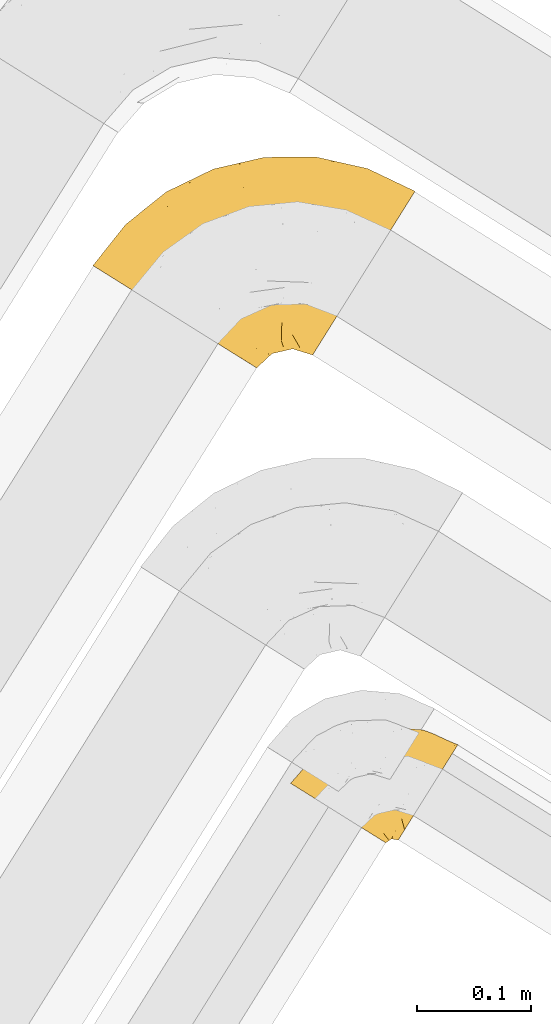
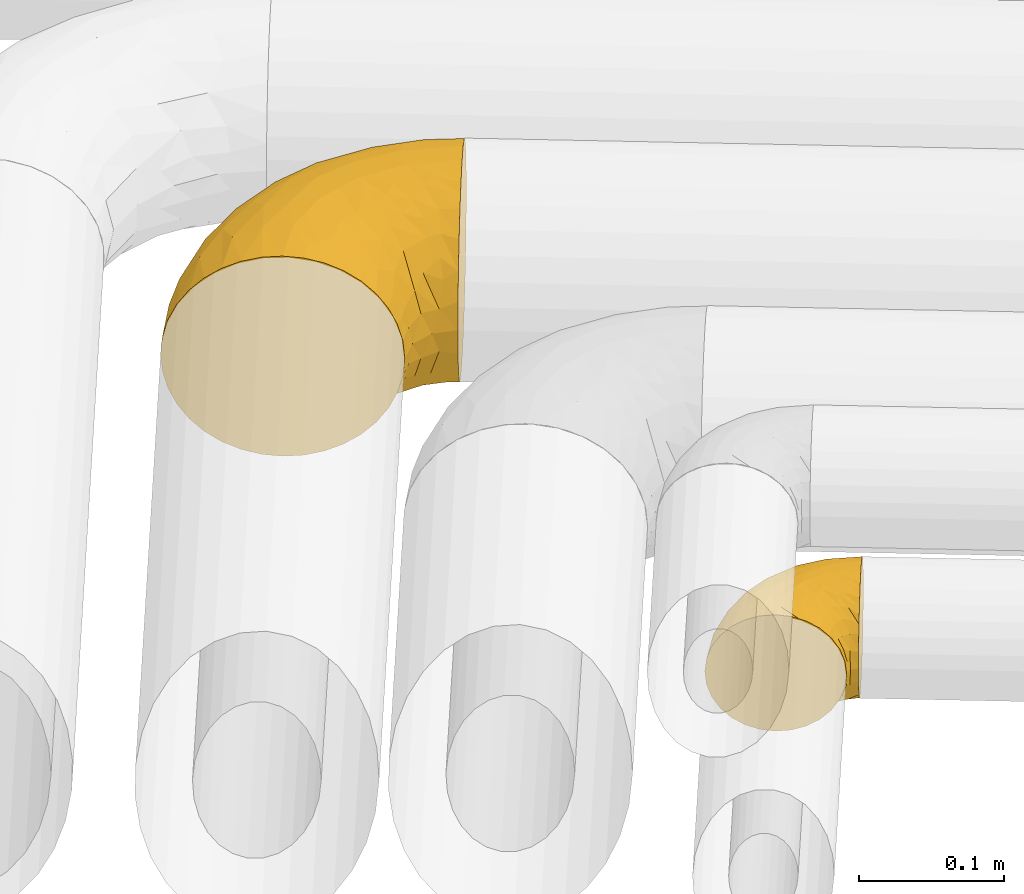
# One storey, part 24 of 93: 2 coverings.
"""IFC2X3 building model written with IfcOpenShell, lengths in millimetres."""

from ifc_helpers import new_model, entity, si_unit, converted_unit, derived_unit, direction, frame, origin, place, context, subcontext, project, spatial, faceted_brep, element, save


model = new_model("IFC2X3")

# Units and contexts
model_context = context("Model", 3, precision=0.01, world=origin(), true_north=direction((6.12303176911189e-17, 1.0)))
body_context = subcontext(model_context, "Body", "Model", "MODEL_VIEW")
ifc_project = project(units=[si_unit("LENGTHUNIT", "METRE", prefix="MILLI"), si_unit("AREAUNIT", "SQUARE_METRE"), si_unit("VOLUMEUNIT", "CUBIC_METRE"), converted_unit("PLANEANGLEUNIT", "DEGREE", entity("IfcRatioMeasure", 0.0174532925199433), si_unit("PLANEANGLEUNIT", "RADIAN"), dimensions=[0, 0, 0, 0, 0, 0, 0]), si_unit("MASSUNIT", "GRAM", prefix="KILO"), derived_unit("MASSDENSITYUNIT", [(si_unit("MASSUNIT", "GRAM", prefix="KILO"), 1), (si_unit("LENGTHUNIT", "METRE"), -3)]), derived_unit("MOMENTOFINERTIAUNIT", [(si_unit("LENGTHUNIT", "METRE"), 4)]), si_unit("TIMEUNIT", "SECOND"), si_unit("FREQUENCYUNIT", "HERTZ"), si_unit("THERMODYNAMICTEMPERATUREUNIT", "DEGREE_CELSIUS"), derived_unit("THERMALTRANSMITTANCEUNIT", [(si_unit("MASSUNIT", "GRAM", prefix="KILO"), 1), (si_unit("THERMODYNAMICTEMPERATUREUNIT", "KELVIN"), -1), (si_unit("TIMEUNIT", "SECOND"), -3)]), derived_unit("VOLUMETRICFLOWRATEUNIT", [(si_unit("LENGTHUNIT", "METRE"), 3), (si_unit("TIMEUNIT", "SECOND"), -1)]), derived_unit("MASSFLOWRATEUNIT", [(si_unit("MASSUNIT", "GRAM", prefix="KILO"), 1), (si_unit("TIMEUNIT", "SECOND"), -1)]), derived_unit("ROTATIONALFREQUENCYUNIT", [(si_unit("TIMEUNIT", "SECOND"), -1)]), si_unit("ELECTRICCURRENTUNIT", "AMPERE"), si_unit("ELECTRICVOLTAGEUNIT", "VOLT"), si_unit("POWERUNIT", "WATT"), si_unit("FORCEUNIT", "NEWTON", prefix="KILO"), si_unit("ILLUMINANCEUNIT", "LUX"), si_unit("LUMINOUSFLUXUNIT", "LUMEN"), si_unit("LUMINOUSINTENSITYUNIT", "CANDELA"), derived_unit("USERDEFINED", [(si_unit("MASSUNIT", "GRAM", prefix="KILO"), -1), (si_unit("LENGTHUNIT", "METRE"), -2), (si_unit("TIMEUNIT", "SECOND"), 3), (si_unit("LUMINOUSFLUXUNIT", "LUMEN"), 1)]), derived_unit("LINEARVELOCITYUNIT", [(si_unit("LENGTHUNIT", "METRE"), 1), (si_unit("TIMEUNIT", "SECOND"), -1)]), si_unit("PRESSUREUNIT", "PASCAL"), derived_unit("USERDEFINED", [(si_unit("LENGTHUNIT", "METRE"), -2), (si_unit("MASSUNIT", "GRAM", prefix="KILO"), 1), (si_unit("TIMEUNIT", "SECOND"), -2)]), derived_unit("LINEARFORCEUNIT", [(si_unit("MASSUNIT", "GRAM", prefix="KILO"), 1), (si_unit("LENGTHUNIT", "METRE"), 1), (si_unit("TIMEUNIT", "SECOND"), -2), (si_unit("LENGTHUNIT", "METRE"), -1)]), derived_unit("PLANARFORCEUNIT", [(si_unit("MASSUNIT", "GRAM", prefix="KILO"), 1), (si_unit("LENGTHUNIT", "METRE"), 1), (si_unit("TIMEUNIT", "SECOND"), -2), (si_unit("LENGTHUNIT", "METRE"), -2)])], contexts=[model_context])

# Site, building, storey
site_placement = place(None, origin())
site = spatial("IfcSite", under=ifc_project, at=site_placement, CompositionType="ELEMENT")
building_placement = place(site_placement, origin())
building = spatial("IfcBuilding", under=site, at=building_placement, CompositionType="ELEMENT")
storey_placement = place(building_placement, frame((0.0, 0.0, -4200.0)))
storey = spatial("IfcBuildingStorey", under=building, at=storey_placement, CompositionType="ELEMENT", Elevation=-4200.0)

# Coverings
covering_1_placement = place(storey_placement, frame((15989.6, 11181.06, 2910.91)))
element("IfcCovering", 1, at=covering_1_placement, inside=storey, Name=":ADSK_", ObjectType=":ADSK_", PredefinedType="INSULATION", context=body_context, shape_type="Brep", body=[
    faceted_brep([(48.74, 61.69, 165.5), (37.42, 68.77, 159.27), (27.19, 75.16, 150.82), (18.36, 80.68, 140.41), (11.2, 85.15, 128.34), (5.92, 88.45, 115.0), (2.68, 90.47, 100.77), (1.6, 91.15, 86.1), (2.68, 90.47, 71.42), (5.92, 88.45, 57.19), (11.2, 85.15, 43.84), (18.36, 80.67, 31.78), (27.19, 75.16, 21.36), (37.43, 68.76, 12.92), (48.75, 61.69, 6.69), (60.81, 54.15, 2.88), (73.26, 46.37, 1.6), (85.7, 38.6, 2.88), (97.77, 31.06, 6.69), (109.09, 23.98, 12.92), (119.32, 17.59, 21.37), (128.15, 12.07, 31.78), (135.31, 7.59, 43.85), (140.59, 4.3, 57.19), (143.83, 2.28, 71.42), (144.92, 1.6, 86.1), (143.83, 2.28, 100.77), (140.59, 4.3, 115.0), (135.31, 7.6, 128.35), (128.15, 12.07, 140.41), (119.32, 17.59, 150.83), (109.09, 23.98, 159.27), (97.77, 31.06, 165.5), (91.73, 34.83, 167.41), (85.7, 38.6, 169.31), (73.26, 46.37, 170.6), (60.81, 54.15, 169.31), (193.83, 12.89, 86.1), (195.36, 15.33, 64.23), (199.83, 22.49, 43.85), (206.95, 33.88, 26.34), (216.22, 48.72, 12.92), (227.02, 66.0, 4.47), (231.48, 73.13, 3.37), (238.61, 84.55, 1.6), (250.2, 103.1, 4.47), (261.0, 120.38, 12.92), (270.27, 135.22, 26.34), (277.39, 146.61, 43.85), (281.86, 153.77, 64.23), (283.39, 156.21, 86.1), (281.86, 153.77, 107.97), (277.39, 146.61, 128.35), (270.27, 135.22, 145.85), (261.0, 120.38, 159.27), (250.2, 103.1, 167.72), (238.61, 84.55, 170.6), (231.48, 73.13, 168.82), (227.02, 66.0, 167.72), (221.62, 57.36, 163.5), (216.22, 48.72, 159.27), (206.95, 33.88, 145.85), (199.83, 22.49, 128.35), (195.36, 15.33, 107.97), (242.08, 175.98, 86.1), (197.41, 186.05, 86.1), (211.24, 182.55, 101.8), (243.27, 174.05, 101.53), (232.04, 173.74, 115.31), (132.92, 159.31, 144.07), (162.05, 153.18, 153.55), (172.26, 167.01, 140.98), (151.62, 185.94, 86.1), (175.13, 185.81, 101.78), (221.31, 133.45, 161.76), (93.97, 146.55, 142.72), (68.18, 120.64, 150.74), (99.34, 132.99, 155.51), (42.65, 108.25, 143.09), (129.5, 179.97, 104.94), (107.0, 175.64, 86.1), (86.22, 163.68, 108.34), (242.47, 143.15, 151.11), (238.28, 161.13, 134.54), (34.65, 122.13, 119.08), (47.1, 140.31, 102.34), (22.74, 115.94, 105.3), (207.37, 119.04, 168.18), (143.27, 120.33, 167.9), (130.07, 94.05, 170.6), (148.36, 98.27, 170.6), (166.65, 102.49, 170.6), (97.33, 113.97, 164.11), (132.87, 138.19, 159.97), (109.81, 101.8, 169.12), (97.89, 74.71, 170.6), (113.98, 84.38, 170.6), (175.28, 123.68, 167.97), (185.35, 100.85, 170.6), (204.05, 99.22, 170.6), (65.79, 155.67, 86.1), (66.99, 142.68, 128.7), (62.12, 96.55, 160.38), (208.66, 156.84, 148.22), (177.07, 137.96, 162.92), (115.87, 168.16, 125.81), (30.06, 127.03, 86.1), (80.47, 86.87, 168.04), (83.1, 57.69, 170.6), (90.49, 66.2, 170.6), (176.48, 180.18, 120.0), (204.06, 168.86, 135.81), (214.43, 94.81, 170.6), (224.8, 90.41, 170.6), (165.14, 56.26, 157.07), (153.06, 49.27, 154.23), (166.9, 41.67, 145.03), (189.26, 69.63, 164.3), (184.41, 86.81, 169.15), (175.62, 78.85, 167.13), (202.84, 76.57, 167.63), (213.82, 78.8, 168.98), (190.18, 54.97, 156.82), (203.08, 55.42, 159.34), (140.03, 30.75, 144.95), (154.9, 32.29, 138.16), (197.17, 41.97, 148.65), (158.35, 14.13, 86.1), (168.34, 19.81, 104.92), (154.92, 13.7, 101.3), (188.8, 24.82, 123.52), (144.55, 18.54, 128.61), (182.63, 19.42, 104.0), (166.46, 25.37, 121.86), (176.23, 30.47, 129.84), (116.4, 38.16, 160.87), (127.68, 32.32, 153.1), (121.24, 57.31, 165.79), (95.17, 50.82, 169.24), (155.97, 19.31, 116.6), (132.5, 68.25, 166.95), (137.12, 50.22, 159.05), (146.42, 69.79, 165.68), (105.3, 51.05, 167.57), (147.82, 11.54, 112.04), (191.15, 32.32, 136.39), (164.05, 73.03, 165.43), (178.19, 61.94, 160.11), (164.0, 88.25, 169.43), (176.26, 18.26, 86.1), (186.78, 44.11, 147.96), (168.33, 19.81, 67.27), (164.74, 85.13, 3.35), (161.63, 68.61, 8.36), (151.27, 81.7, 3.59), (154.91, 13.7, 70.9), (174.83, 40.25, 29.26), (162.6, 36.58, 31.85), (165.39, 51.07, 18.75), (182.63, 19.42, 68.18), (144.27, 18.1, 43.83), (139.22, 29.24, 27.99), (175.53, 69.91, 8.25), (196.71, 37.53, 27.75), (185.46, 45.11, 23.54), (195.54, 51.09, 17.03), (150.78, 30.4, 34.05), (213.6, 76.44, 3.69), (203.36, 60.46, 10.28), (199.88, 80.55, 3.79), (189.26, 69.63, 7.89), (178.46, 86.78, 3.11), (97.81, 53.03, 3.05), (155.97, 19.31, 55.6), (166.65, 102.49, 1.6), (147.82, 11.54, 60.15), (150.8, 47.81, 18.43), (83.1, 57.69, 1.6), (90.49, 66.2, 1.6), (214.43, 94.81, 1.6), (224.8, 90.41, 1.6), (127.5, 31.71, 19.33), (118.29, 46.8, 8.94), (181.25, 28.65, 44.79), (121.31, 68.27, 3.77), (108.85, 62.71, 3.17), (135.34, 51.54, 11.99), (138.6, 80.42, 3.08), (148.36, 98.27, 1.6), (97.89, 74.71, 1.6), (167.25, 26.47, 48.4), (146.07, 66.09, 7.81), (113.98, 84.38, 1.6), (130.07, 94.05, 1.6), (204.05, 99.22, 1.6), (185.35, 100.85, 1.6), (143.27, 120.33, 4.29), (176.18, 117.83, 2.95), (99.34, 132.98, 16.68), (62.13, 96.54, 11.81), (68.18, 120.63, 21.44), (175.13, 185.81, 70.41), (211.24, 182.55, 70.39), (176.48, 180.18, 52.19), (207.37, 119.03, 4.01), (177.07, 137.96, 9.27), (132.86, 138.19, 12.22), (221.31, 133.45, 10.43), (93.97, 146.55, 29.47), (132.93, 159.31, 28.12), (243.27, 174.05, 70.66), (80.48, 86.87, 4.15), (86.22, 163.68, 63.85), (129.5, 179.97, 67.25), (115.88, 168.16, 46.37), (232.04, 173.74, 56.88), (66.99, 142.69, 43.49), (242.47, 143.15, 21.08), (208.66, 156.84, 23.97), (204.05, 168.86, 36.39), (238.28, 161.13, 37.65), (42.66, 108.24, 29.09), (109.81, 101.8, 3.07), (97.33, 113.96, 8.08), (162.05, 153.18, 18.64), (172.26, 167.0, 31.2), (34.65, 122.13, 53.1), (47.1, 140.31, 69.85), (22.74, 115.94, 66.89)], [[[0, 1, 2, 3, 4, 5, 6, 7, 8, 9, 10, 11, 12, 13, 14, 15, 16, 17, 18, 19, 20, 21, 22, 23, 24, 25, 26, 27, 28, 29, 30, 31, 32, 33, 34, 35, 36]], [[37, 38, 39, 40, 41, 42, 43, 44, 45, 46, 47, 48, 49, 50, 51, 52, 53, 54, 55, 56, 57, 58, 59, 60, 61, 62, 63]], [[64, 65, 66]], [[67, 50, 64]], [[68, 52, 51]], [[69, 70, 71]], [[72, 73, 65]], [[54, 74, 55]], [[75, 76, 77]], [[65, 73, 66]], [[2, 78, 3]], [[79, 80, 81]], [[53, 82, 54]], [[53, 52, 83]], [[52, 68, 83]], [[84, 85, 86]], [[74, 87, 55]], [[88, 89, 90, 91]], [[92, 93, 77]], [[56, 55, 87]], [[94, 95, 96, 89]], [[92, 88, 93]], [[97, 91, 98, 99]], [[93, 70, 69]], [[81, 80, 100]], [[101, 81, 85]], [[76, 1, 102]], [[74, 103, 104]], [[5, 4, 84]], [[84, 4, 78]], [[80, 79, 72]], [[84, 86, 5]], [[77, 102, 92]], [[3, 78, 4]], [[101, 75, 105]], [[106, 7, 6]], [[100, 106, 85]], [[76, 78, 2]], [[107, 35, 108, 109, 95]], [[107, 95, 94]], [[94, 88, 92]], [[79, 105, 110]], [[71, 103, 111]], [[0, 107, 102]], [[84, 78, 101]], [[97, 99, 87]], [[66, 67, 64]], [[1, 76, 2]], [[0, 102, 1]], [[76, 101, 78]], [[107, 0, 36]], [[81, 100, 85]], [[88, 94, 89]], [[93, 88, 104]], [[107, 94, 92]], [[105, 79, 81]], [[73, 79, 110]], [[101, 105, 81]], [[105, 69, 71]], [[111, 68, 110]], [[82, 83, 103]], [[102, 107, 92]], [[107, 36, 35]], [[74, 54, 82]], [[87, 74, 104]], [[97, 87, 104]], [[87, 99, 112, 113, 56]], [[70, 93, 104]], [[77, 76, 102]], [[86, 106, 6]], [[85, 84, 101]], [[79, 73, 72]], [[66, 110, 68]], [[110, 66, 73]], [[66, 68, 67]], [[68, 51, 67]], [[50, 67, 51]], [[104, 103, 70]], [[71, 70, 103]], [[111, 103, 83]], [[105, 71, 110]], [[68, 111, 83]], [[110, 71, 111]], [[93, 69, 77]], [[75, 77, 69]], [[105, 75, 69]], [[101, 76, 75]], [[106, 86, 85]], [[5, 86, 6]], [[83, 82, 53]], [[74, 82, 103]], [[104, 88, 97]], [[91, 97, 88]], [[114, 115, 116]], [[113, 112, 58, 57, 56]], [[117, 118, 119]], [[120, 121, 99]], [[120, 99, 98]], [[117, 122, 123]], [[124, 125, 115]], [[62, 61, 126]], [[127, 128, 129]], [[115, 125, 116]], [[130, 63, 62]], [[28, 131, 124]], [[132, 37, 63]], [[133, 132, 134]], [[135, 136, 137]], [[138, 108, 34]], [[128, 139, 129]], [[89, 96, 140]], [[140, 141, 142]], [[32, 31, 143]], [[34, 33, 32, 138]], [[29, 124, 136]], [[141, 124, 115]], [[135, 31, 30]], [[116, 125, 133]], [[35, 34, 108]], [[28, 27, 131]], [[124, 141, 136]], [[144, 131, 27]], [[127, 129, 25]], [[139, 144, 129]], [[95, 109, 108, 138]], [[134, 130, 145]], [[28, 124, 29]], [[29, 136, 30]], [[121, 120, 59]], [[27, 26, 144]], [[124, 131, 125]], [[146, 114, 147]], [[115, 114, 142]], [[131, 139, 125]], [[117, 147, 122]], [[125, 139, 133]], [[135, 143, 31]], [[143, 137, 96]], [[142, 90, 89]], [[137, 136, 141]], [[146, 119, 148]], [[115, 142, 141]], [[119, 146, 147]], [[142, 146, 148]], [[141, 140, 137]], [[26, 25, 129]], [[131, 144, 139]], [[136, 135, 30]], [[143, 135, 137]], [[26, 129, 144]], [[128, 127, 149]], [[132, 128, 149]], [[133, 139, 128]], [[37, 132, 149]], [[132, 63, 130]], [[134, 150, 116]], [[119, 147, 117]], [[150, 114, 116]], [[142, 114, 146]], [[114, 150, 147]], [[122, 147, 150]], [[98, 118, 120]], [[148, 119, 91]], [[118, 117, 120]], [[119, 118, 91]], [[91, 118, 98]], [[123, 120, 117]], [[58, 112, 121]], [[91, 90, 148]], [[142, 148, 90]], [[132, 133, 128]], [[133, 134, 116]], [[142, 89, 140]], [[95, 143, 96]], [[150, 126, 122]], [[123, 61, 60]], [[123, 122, 126]], [[120, 123, 60]], [[126, 150, 145]], [[123, 126, 61]], [[140, 96, 137]], [[145, 130, 62]], [[132, 130, 134]], [[126, 145, 62]], [[134, 145, 150]], [[32, 143, 138]], [[95, 138, 143]], [[121, 112, 99]], [[120, 60, 59]], [[58, 121, 59]], [[149, 127, 151]], [[152, 153, 154]], [[127, 155, 151]], [[156, 157, 158]], [[159, 149, 151]], [[159, 37, 149]], [[160, 22, 161]], [[153, 152, 162]], [[163, 164, 165]], [[166, 160, 161]], [[167, 41, 168]], [[169, 170, 171]], [[169, 168, 170]], [[168, 165, 170]], [[172, 19, 18]], [[166, 173, 160]], [[174, 171, 152]], [[24, 175, 155]], [[176, 158, 157]], [[17, 16, 177, 178]], [[42, 167, 179]], [[160, 23, 22]], [[175, 24, 23]], [[180, 44, 43, 42, 179]], [[20, 181, 21]], [[182, 20, 19]], [[21, 181, 161]], [[21, 161, 22]], [[39, 38, 183]], [[184, 182, 185]], [[186, 161, 181]], [[172, 18, 17]], [[187, 188, 154]], [[161, 176, 166]], [[185, 19, 172]], [[178, 189, 172]], [[178, 172, 17]], [[151, 173, 190]], [[164, 163, 183]], [[155, 25, 24]], [[166, 176, 157]], [[175, 160, 173]], [[153, 176, 191]], [[20, 182, 181]], [[186, 181, 182]], [[185, 182, 19]], [[172, 189, 185]], [[189, 192, 185]], [[187, 184, 193]], [[184, 185, 192]], [[160, 175, 23]], [[155, 175, 173]], [[155, 173, 151]], [[155, 127, 25]], [[173, 166, 190]], [[159, 183, 38]], [[193, 184, 192]], [[186, 182, 184]], [[159, 151, 190]], [[37, 159, 38]], [[176, 161, 186]], [[166, 157, 190]], [[191, 176, 186]], [[158, 176, 153]], [[187, 186, 184]], [[191, 154, 153]], [[156, 190, 157]], [[188, 152, 154]], [[159, 190, 183]], [[162, 158, 153]], [[156, 158, 164]], [[164, 183, 156]], [[190, 156, 183]], [[187, 154, 191]], [[152, 188, 174]], [[171, 170, 162]], [[152, 171, 162]], [[167, 169, 194]], [[169, 195, 194]], [[169, 167, 168]], [[174, 195, 171]], [[169, 171, 195]], [[165, 162, 170]], [[158, 162, 164]], [[187, 191, 186]], [[188, 187, 193]], [[41, 167, 42]], [[41, 40, 168]], [[165, 164, 162]], [[168, 40, 165]], [[163, 165, 40]], [[40, 39, 163]], [[183, 163, 39]], [[167, 194, 179]], [[196, 197, 174]], [[198, 199, 200]], [[201, 202, 203]], [[204, 44, 180, 179, 194]], [[205, 196, 206]], [[204, 205, 207]], [[204, 197, 205]], [[196, 174, 188, 193]], [[198, 208, 209]], [[65, 201, 72]], [[50, 49, 210]], [[211, 189, 178, 177, 16]], [[212, 213, 214]], [[49, 48, 215]], [[214, 216, 212]], [[217, 207, 218]], [[217, 47, 46]], [[210, 215, 202]], [[199, 13, 200]], [[219, 215, 220]], [[213, 80, 72]], [[221, 12, 11]], [[222, 193, 192, 189]], [[199, 223, 211]], [[16, 15, 211]], [[212, 100, 80]], [[216, 200, 221]], [[199, 211, 14]], [[14, 13, 199]], [[206, 196, 223]], [[12, 221, 200]], [[218, 224, 225]], [[222, 196, 193]], [[13, 12, 200]], [[221, 11, 10]], [[10, 226, 221]], [[80, 213, 212]], [[226, 227, 216]], [[212, 216, 227]], [[226, 10, 9]], [[228, 106, 227]], [[100, 227, 106]], [[7, 106, 8]], [[48, 220, 215]], [[228, 9, 8]], [[216, 221, 226]], [[223, 198, 206]], [[45, 207, 46]], [[206, 224, 205]], [[223, 222, 211]], [[48, 47, 220]], [[64, 210, 202]], [[196, 222, 223]], [[201, 213, 72]], [[203, 225, 214]], [[203, 214, 213]], [[214, 209, 208]], [[217, 220, 47]], [[218, 225, 219]], [[189, 211, 222]], [[211, 15, 14]], [[45, 44, 204]], [[218, 207, 205]], [[45, 204, 207]], [[197, 194, 195, 174]], [[223, 199, 198]], [[224, 206, 209]], [[212, 227, 100]], [[228, 227, 226]], [[202, 201, 65]], [[213, 201, 203]], [[64, 202, 65]], [[203, 202, 215]], [[50, 210, 64]], [[49, 215, 210]], [[225, 224, 209]], [[218, 205, 224]], [[214, 225, 209]], [[218, 219, 220]], [[225, 203, 219]], [[215, 219, 203]], [[208, 198, 200]], [[209, 206, 198]], [[200, 216, 208]], [[214, 208, 216]], [[9, 228, 226]], [[106, 228, 8]], [[207, 217, 46]], [[220, 217, 218]], [[205, 197, 196]], [[194, 197, 204]]]),
])
covering_2_placement = place(storey_placement, frame((16162.57, 10765.44, 2892.1)))
element("IfcCovering", 2, at=covering_2_placement, inside=storey, Name=":ADSK_", ObjectType=":ADSK_", PredefinedType="INSULATION", context=body_context, shape_type="Brep", body=[
    faceted_brep([(43.28, 27.64, 99.9), (34.0, 33.44, 98.66), (25.19, 38.95, 95.02), (17.28, 43.88, 89.17), (10.68, 48.01, 81.38), (5.72, 51.11, 72.06), (2.64, 53.03, 61.68), (1.6, 53.69, 50.75), (2.64, 53.03, 39.8), (5.73, 51.11, 29.41), (10.69, 48.0, 20.09), (17.29, 43.88, 12.31), (25.2, 38.94, 6.46), (34.01, 33.43, 2.83), (43.28, 27.64, 1.6), (48.11, 24.62, 2.24), (52.56, 21.84, 2.83), (56.96, 19.09, 4.65), (61.37, 16.34, 6.47), (69.27, 11.4, 12.32), (75.87, 7.27, 20.11), (80.83, 4.17, 29.43), (83.91, 2.25, 39.81), (84.96, 1.6, 50.75), (83.91, 2.25, 61.69), (80.83, 4.18, 72.08), (75.86, 7.28, 81.4), (69.26, 11.41, 89.18), (61.36, 16.34, 95.03), (56.95, 19.1, 96.85), (52.55, 21.85, 98.66), (48.11, 24.62, 99.25), (45.69, 26.13, 99.57), (96.66, 5.51, 38.02), (99.26, 9.68, 26.17), (101.33, 12.99, 21.08), (103.4, 16.3, 15.99), (106.1, 20.62, 12.09), (108.8, 24.93, 8.18), (111.94, 29.96, 5.73), (115.08, 34.99, 3.27), (118.78, 40.91, 2.35), (120.3, 43.34, 1.97), (121.82, 45.77, 1.6), (128.56, 56.56, 3.27), (134.84, 66.61, 8.18), (140.24, 75.25, 15.99), (144.38, 81.87, 26.17), (146.98, 86.04, 38.02), (147.87, 87.46, 50.75), (146.98, 86.04, 63.47), (144.38, 81.87, 75.32), (140.24, 75.25, 85.5), (134.84, 66.61, 93.31), (128.56, 56.56, 98.22), (121.82, 45.77, 99.9), (118.78, 40.91, 99.14), (115.08, 34.99, 98.22), (111.94, 29.96, 95.77), (108.8, 24.93, 93.31), (106.1, 20.62, 89.4), (103.4, 16.3, 85.5), (101.33, 12.99, 80.41), (99.26, 9.68, 75.32), (96.66, 5.51, 63.47), (95.78, 4.09, 50.75), (76.15, 101.69, 59.31), (86.12, 98.07, 73.08), (97.37, 101.68, 63.72), (117.3, 100.43, 50.75), (127.85, 96.53, 58.64), (136.6, 92.24, 50.75), (105.59, 95.16, 76.74), (123.77, 95.43, 67.68), (126.45, 88.25, 78.92), (51.16, 66.17, 94.31), (48.0, 48.95, 98.76), (65.59, 61.39, 98.4), (113.14, 73.71, 94.57), (92.83, 84.12, 89.91), (85.54, 72.58, 96.32), (109.18, 62.49, 98.79), (101.02, 53.65, 99.9), (106.25, 51.67, 99.9), (111.49, 49.69, 99.9), (114.07, 48.71, 99.9), (116.65, 47.73, 99.9), (115.97, 83.91, 87.31), (37.46, 52.28, 95.61), (37.0, 87.33, 60.43), (19.1, 71.93, 65.24), (36.96, 82.24, 72.87), (58.52, 43.84, 99.9), (63.58, 46.12, 99.9), (68.65, 48.41, 99.9), (73.72, 50.69, 99.9), (78.79, 52.97, 99.9), (30.82, 57.84, 90.65), (52.79, 94.52, 63.14), (74.56, 79.56, 91.89), (18.31, 64.87, 75.25), (9.62, 62.92, 50.75), (89.52, 92.19, 82.18), (70.56, 87.16, 85.08), (69.09, 93.42, 76.93), (51.85, 95.86, 50.75), (68.03, 99.59, 50.75), (28.09, 66.81, 83.02), (45.17, 29.65, 99.9), (47.06, 31.67, 99.9), (50.85, 35.69, 99.9), (54.68, 39.77, 99.9), (46.17, 75.16, 87.13), (53.78, 85.5, 80.85), (87.81, 62.75, 99.17), (23.38, 78.75, 50.75), (84.35, 53.14, 99.9), (89.91, 53.31, 99.9), (95.47, 53.48, 99.9), (84.21, 103.33, 50.75), (68.41, 97.96, 67.61), (53.46, 91.16, 72.25), (37.62, 87.3, 50.75), (100.75, 101.88, 50.75), (57.74, 28.83, 98.69), (110.54, 41.26, 99.01), (100.55, 43.22, 98.79), (106.06, 39.57, 98.29), (85.4, 6.72, 68.51), (82.87, 10.04, 76.82), (67.53, 36.06, 98.54), (62.5, 37.29, 99.3), (96.52, 17.26, 83.57), (98.68, 23.22, 89.47), (93.22, 12.04, 75.76), (91.2, 19.05, 84.86), (86.86, 11.41, 75.89), (90.98, 7.31, 64.77), (82.81, 24.61, 90.83), (77.49, 29.29, 94.62), (77.11, 21.29, 90.37), (102.39, 24.43, 91.18), (100.73, 33.08, 95.55), (73.99, 16.15, 88.65), (79.77, 14.66, 84.11), (87.63, 27.07, 91.75), (64.27, 26.64, 96.86), (89.85, 5.08, 50.75), (87.07, 4.67, 58.97), (73.38, 38.42, 98.37), (84.01, 16.72, 83.91), (81.43, 38.09, 97.52), (95.38, 43.77, 98.76), (95.28, 33.4, 95.26), (88.08, 40.92, 98.04), (93.2, 25.7, 90.65), (69.26, 21.4, 93.51), (73.01, 25.85, 94.16), (90.72, 45.63, 99.1), (93.22, 12.04, 25.73), (93.21, 25.69, 10.84), (96.53, 17.26, 17.92), (91.22, 19.04, 16.64), (84.03, 7.04, 30.44), (67.53, 36.07, 2.95), (62.5, 37.28, 2.19), (63.58, 46.12, 1.6), (64.29, 26.63, 4.63), (79.78, 14.66, 17.39), (119.24, 46.75, 1.6), (111.49, 49.69, 1.6), (116.65, 47.73, 1.6), (74.01, 16.14, 12.86), (77.13, 21.29, 11.13), (106.06, 39.57, 3.2), (100.73, 33.08, 5.94), (98.68, 23.22, 12.02), (95.28, 33.4, 6.23), (102.39, 24.43, 10.31), (69.29, 21.37, 8.0), (73.02, 25.84, 7.34), (110.54, 41.26, 2.48), (95.38, 43.77, 2.73), (100.49, 43.51, 2.64), (50.85, 35.69, 1.6), (57.75, 28.84, 2.8), (90.99, 7.31, 36.71), (106.25, 51.67, 1.6), (101.02, 53.65, 1.6), (86.97, 5.58, 38.59), (47.06, 31.67, 1.6), (48.96, 33.68, 1.6), (68.65, 48.41, 1.6), (73.38, 38.41, 3.12), (84.02, 16.71, 17.59), (73.72, 50.69, 1.6), (81.46, 38.06, 3.98), (77.5, 29.3, 6.87), (88.08, 40.91, 3.45), (87.65, 27.04, 9.76), (54.68, 39.77, 1.6), (58.52, 43.84, 1.6), (86.87, 11.41, 25.62), (82.83, 24.6, 10.67), (90.72, 45.63, 2.39), (89.91, 53.31, 1.6), (95.47, 53.48, 1.6), (84.35, 53.14, 1.6), (78.79, 52.97, 1.6), (87.71, 63.16, 2.4), (127.85, 96.53, 42.85), (115.97, 83.91, 14.18), (93.19, 84.09, 11.56), (89.56, 92.17, 19.27), (105.59, 95.16, 24.75), (86.07, 98.05, 28.37), (37.16, 52.18, 5.95), (47.91, 49.24, 2.79), (109.18, 62.49, 2.71), (97.37, 101.68, 37.78), (123.77, 95.43, 33.81), (126.45, 88.26, 22.57), (113.14, 73.71, 6.92), (36.96, 82.23, 28.61), (19.1, 71.93, 36.24), (37.01, 87.34, 41.05), (69.0, 93.4, 24.55), (68.41, 97.96, 33.88), (50.66, 65.72, 7.11), (52.83, 94.55, 38.38), (76.15, 101.69, 42.18), (28.1, 66.81, 18.46), (30.83, 57.83, 10.84), (53.65, 85.49, 20.69), (53.43, 91.17, 29.27), (65.59, 61.42, 3.1), (68.34, 77.34, 9.18), (18.32, 64.87, 26.23), (46.34, 75.25, 14.34), (85.39, 73.28, 5.46), (70.56, 87.15, 16.39)], [[[0, 1, 2, 3, 4, 5, 6, 7, 8, 9, 10, 11, 12, 13, 14, 15, 16, 17, 18, 19, 20, 21, 22, 23, 24, 25, 26, 27, 28, 29, 30, 31, 32]], [[33, 34, 35, 36, 37, 38, 39, 40, 41, 42, 43, 44, 45, 46, 47, 48, 49, 50, 51, 52, 53, 54, 55, 56, 57, 58, 59, 60, 61, 62, 63, 64, 65]], [[66, 67, 68]], [[69, 70, 71]], [[68, 72, 73]], [[73, 72, 74]], [[75, 76, 77]], [[78, 79, 80]], [[51, 50, 73]], [[81, 82, 83, 84, 85, 86, 55]], [[52, 87, 53]], [[74, 52, 51]], [[2, 1, 88]], [[89, 90, 91]], [[77, 92, 93, 94, 95, 96]], [[55, 54, 81]], [[78, 53, 87]], [[5, 90, 6]], [[88, 76, 75]], [[97, 3, 2]], [[89, 91, 98]], [[99, 80, 79]], [[90, 5, 100]], [[74, 87, 52]], [[100, 5, 4]], [[90, 101, 6]], [[79, 102, 103]], [[102, 67, 104]], [[105, 98, 106]], [[107, 4, 3]], [[76, 0, 108, 109, 110, 111, 92]], [[107, 112, 113]], [[114, 77, 96]], [[89, 115, 90]], [[114, 96, 116, 117, 118, 82]], [[75, 97, 88]], [[119, 66, 68]], [[50, 71, 70]], [[100, 91, 90]], [[99, 77, 80]], [[102, 104, 103]], [[97, 107, 3]], [[80, 81, 78]], [[107, 97, 112]], [[68, 73, 70]], [[66, 98, 120]], [[78, 81, 54]], [[114, 81, 80]], [[53, 78, 54]], [[78, 87, 79]], [[102, 87, 72]], [[79, 103, 99]], [[4, 107, 100]], [[91, 100, 107]], [[88, 97, 2]], [[112, 97, 75]], [[99, 112, 75]], [[103, 104, 113]], [[91, 121, 98]], [[89, 105, 122, 115]], [[101, 90, 115]], [[101, 7, 6]], [[88, 1, 76]], [[0, 76, 1]], [[92, 77, 76]], [[73, 74, 51]], [[87, 74, 72]], [[81, 114, 82]], [[77, 114, 80]], [[87, 102, 79]], [[67, 102, 72]], [[68, 67, 72]], [[67, 120, 104]], [[120, 121, 104]], [[104, 121, 113]], [[121, 120, 98]], [[91, 107, 113]], [[91, 113, 121]], [[103, 113, 112]], [[106, 98, 66]], [[105, 89, 98]], [[106, 66, 119]], [[67, 66, 120]], [[68, 69, 123, 119]], [[50, 49, 71]], [[50, 70, 73]], [[112, 99, 103]], [[77, 99, 75]], [[69, 68, 70]], [[29, 124, 110]], [[84, 83, 125]], [[126, 82, 118]], [[59, 58, 127]], [[25, 128, 129]], [[130, 93, 131]], [[132, 62, 133]], [[134, 135, 136]], [[137, 65, 64]], [[64, 134, 137]], [[138, 139, 140]], [[111, 110, 124, 92]], [[134, 136, 137]], [[134, 64, 63]], [[141, 60, 142]], [[125, 58, 57]], [[143, 144, 140]], [[143, 26, 144]], [[127, 83, 82]], [[28, 124, 29]], [[108, 0, 32, 31, 30, 110, 109]], [[30, 29, 110]], [[135, 145, 138]], [[28, 146, 124]], [[57, 56, 55, 86, 85, 84]], [[147, 148, 23]], [[24, 23, 148]], [[25, 144, 26]], [[95, 94, 149]], [[24, 128, 25]], [[150, 138, 144]], [[124, 146, 131]], [[127, 58, 125]], [[151, 149, 139]], [[127, 126, 142]], [[142, 59, 127]], [[152, 142, 126]], [[153, 154, 155]], [[153, 133, 141]], [[146, 28, 27]], [[143, 156, 27]], [[157, 149, 130]], [[61, 133, 62]], [[134, 132, 135]], [[148, 128, 24]], [[65, 137, 147]], [[147, 137, 148]], [[128, 137, 136]], [[137, 128, 148]], [[128, 136, 129]], [[150, 129, 136]], [[25, 129, 144]], [[158, 152, 117]], [[152, 118, 117]], [[153, 142, 152]], [[158, 116, 154]], [[145, 151, 138]], [[153, 152, 158]], [[133, 153, 155]], [[133, 155, 132]], [[153, 141, 142]], [[135, 132, 155]], [[134, 63, 132]], [[145, 135, 155]], [[135, 138, 150]], [[155, 154, 145]], [[151, 154, 96]], [[154, 151, 145]], [[149, 94, 130]], [[82, 126, 127]], [[118, 152, 126]], [[151, 96, 95]], [[139, 149, 157]], [[151, 95, 149]], [[93, 92, 131]], [[130, 146, 156]], [[130, 94, 93]], [[84, 125, 57]], [[127, 125, 83]], [[140, 139, 157]], [[151, 139, 138]], [[140, 157, 143]], [[138, 140, 144]], [[156, 143, 157]], [[27, 26, 143]], [[130, 156, 157]], [[146, 27, 156]], [[132, 63, 62]], [[124, 131, 92]], [[130, 131, 146]], [[129, 150, 144]], [[135, 150, 136]], [[60, 141, 61]], [[60, 59, 142]], [[133, 61, 141]], [[116, 96, 154]], [[153, 158, 154]], [[158, 117, 116]], [[34, 33, 159]], [[160, 161, 162]], [[22, 21, 163]], [[164, 165, 166]], [[19, 18, 167]], [[168, 21, 20]], [[169, 43, 42, 41, 40, 170, 171]], [[172, 173, 168]], [[174, 38, 175]], [[176, 177, 178]], [[179, 164, 180]], [[40, 181, 170]], [[182, 183, 175]], [[17, 184, 185]], [[65, 147, 186]], [[187, 174, 188]], [[23, 22, 189]], [[174, 39, 38]], [[15, 14, 190, 191, 184, 16]], [[181, 40, 39]], [[192, 193, 164]], [[194, 163, 168]], [[33, 186, 159]], [[180, 173, 172]], [[195, 196, 193]], [[18, 185, 167]], [[173, 180, 197]], [[198, 199, 196]], [[200, 201, 185, 184]], [[184, 17, 16]], [[18, 17, 185]], [[202, 159, 186]], [[194, 168, 203]], [[189, 163, 202]], [[204, 205, 182]], [[187, 181, 174]], [[160, 177, 176]], [[206, 183, 182]], [[206, 182, 205]], [[201, 165, 185]], [[165, 164, 167]], [[172, 179, 180]], [[202, 194, 162]], [[176, 161, 160]], [[65, 186, 33]], [[163, 189, 22]], [[175, 177, 182]], [[174, 183, 188]], [[177, 198, 204]], [[199, 160, 162]], [[198, 207, 204]], [[175, 38, 37]], [[198, 177, 160]], [[178, 177, 175]], [[176, 35, 161]], [[34, 159, 161]], [[162, 161, 159]], [[202, 162, 159]], [[199, 162, 203]], [[196, 199, 203]], [[198, 160, 199]], [[193, 197, 180]], [[208, 198, 196]], [[188, 183, 206]], [[175, 183, 174]], [[193, 192, 195]], [[195, 208, 196]], [[197, 196, 203]], [[180, 164, 193]], [[168, 163, 21]], [[166, 165, 201]], [[166, 192, 164]], [[189, 202, 186]], [[186, 147, 189]], [[23, 189, 147]], [[174, 181, 39]], [[170, 181, 187]], [[196, 197, 193]], [[173, 203, 168]], [[203, 173, 197]], [[172, 168, 20]], [[20, 19, 172]], [[179, 172, 19]], [[19, 167, 179]], [[164, 179, 167]], [[35, 176, 36]], [[35, 34, 161]], [[185, 165, 167]], [[162, 194, 203]], [[163, 194, 202]], [[176, 178, 36]], [[37, 36, 178]], [[175, 37, 178]], [[177, 204, 182]], [[207, 198, 208]], [[207, 205, 204]], [[209, 188, 206, 205, 207, 208]], [[48, 210, 71]], [[211, 212, 213]], [[214, 213, 215]], [[216, 217, 13]], [[218, 43, 169, 171, 170, 187, 188]], [[219, 220, 214]], [[47, 46, 221]], [[210, 48, 220]], [[211, 222, 212]], [[222, 45, 44]], [[221, 220, 47]], [[47, 220, 48]], [[221, 211, 214]], [[223, 224, 225]], [[211, 46, 45]], [[226, 227, 215]], [[43, 218, 44]], [[217, 216, 228]], [[227, 229, 230]], [[14, 13, 217]], [[224, 9, 8]], [[10, 231, 11]], [[11, 232, 12]], [[233, 223, 234]], [[235, 208, 195, 192, 166, 201]], [[236, 235, 228]], [[222, 44, 218]], [[106, 230, 229]], [[224, 237, 9]], [[232, 238, 228]], [[9, 237, 10]], [[115, 224, 101]], [[239, 235, 236]], [[232, 11, 231]], [[223, 231, 237]], [[224, 8, 101]], [[223, 229, 234]], [[225, 115, 122, 105]], [[216, 12, 232]], [[209, 235, 239]], [[210, 219, 69]], [[219, 214, 215]], [[230, 119, 219]], [[209, 218, 188]], [[239, 212, 222]], [[239, 222, 218]], [[45, 222, 211]], [[236, 212, 239]], [[213, 212, 240]], [[223, 237, 224]], [[231, 10, 237]], [[238, 232, 231]], [[216, 232, 228]], [[233, 231, 223]], [[236, 238, 240]], [[115, 225, 224]], [[234, 229, 227]], [[8, 7, 101]], [[235, 209, 208]], [[218, 209, 239]], [[217, 228, 235]], [[13, 12, 216]], [[235, 201, 217]], [[217, 201, 200, 184, 191, 190, 14]], [[211, 221, 46]], [[220, 221, 214]], [[71, 210, 69]], [[71, 49, 48]], [[219, 210, 220]], [[226, 215, 213]], [[211, 213, 214]], [[226, 213, 240]], [[215, 227, 230]], [[233, 240, 238]], [[234, 227, 226]], [[233, 234, 226]], [[229, 223, 225]], [[240, 233, 226]], [[233, 238, 231]], [[225, 105, 229]], [[229, 105, 106]], [[106, 119, 230]], [[123, 69, 219, 119]], [[215, 230, 219]], [[238, 236, 228]], [[212, 236, 240]]]),
])

save(model, "model.ifc")
